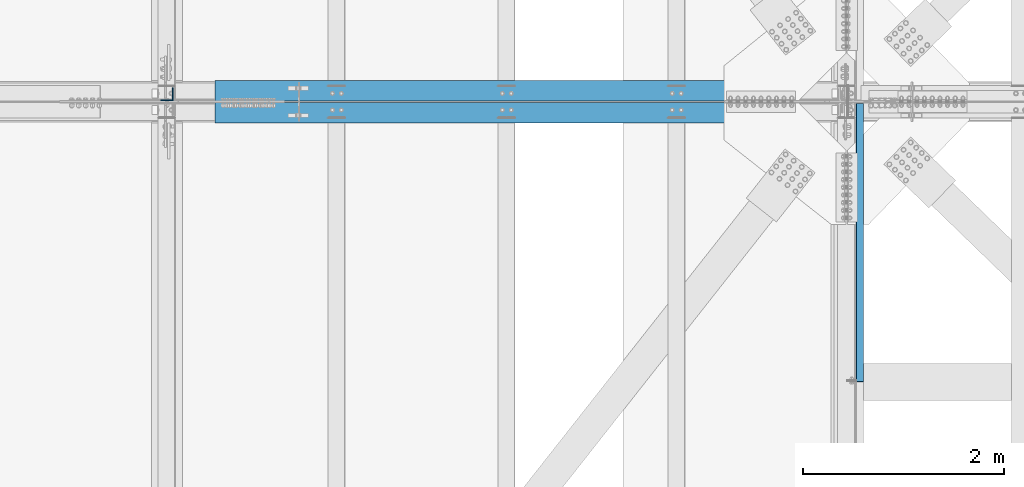
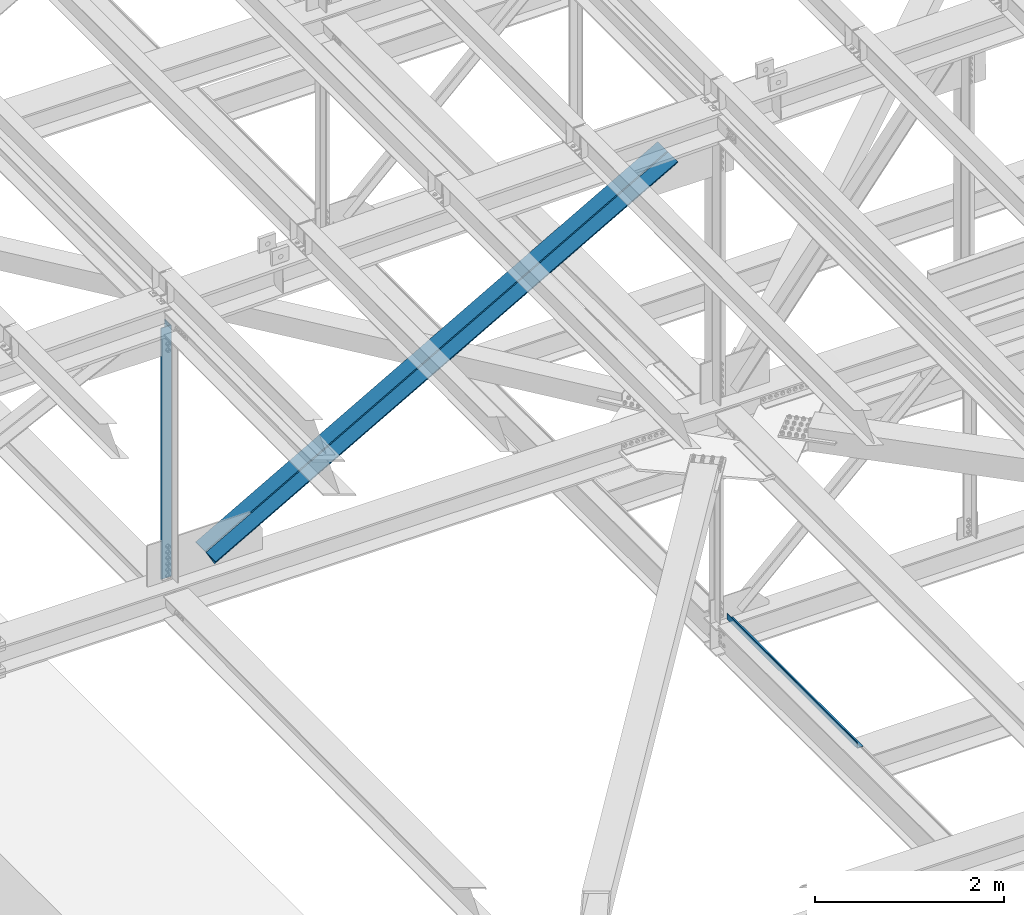
# One storey, part 1839 of 3843: 2 beams, 2 members, 4 elements without a shape of their own.
"""IFC2X3 building model written with IfcOpenShell, lengths in millimetres."""

from ifc_helpers import new_model, si_unit, frame, origin_with_axes, place, context, subcontext, project, spatial, faceted_brep, material, type_object, element, aggregate, save


model = new_model("IFC2X3")

# Units and contexts
model_context = context("Model", 3, precision=1e-05, world=origin_with_axes())
body_context = subcontext(model_context, "Body", "Model", "MODEL_VIEW")
ifc_project = project(units=[si_unit("LENGTHUNIT", "METRE", prefix="MILLI"), si_unit("AREAUNIT", "SQUARE_METRE"), si_unit("VOLUMEUNIT", "CUBIC_METRE"), si_unit("MASSUNIT", "GRAM", prefix="KILO"), si_unit("TIMEUNIT", "SECOND"), si_unit("PLANEANGLEUNIT", "RADIAN"), si_unit("SOLIDANGLEUNIT", "STERADIAN"), si_unit("THERMODYNAMICTEMPERATUREUNIT", "DEGREE_CELSIUS"), si_unit("LUMINOUSINTENSITYUNIT", "LUMEN")], contexts=[model_context])

# Site, building, storey
site_placement = place(None, origin_with_axes())
site = spatial("IfcSite", under=ifc_project, at=site_placement, CompositionType="ELEMENT")
building_placement = place(site_placement, origin_with_axes())
building = spatial("IfcBuilding", under=site, at=building_placement, Name="Undefined", CompositionType="ELEMENT")
storey_placement = place(building_placement, origin_with_axes())
storey = spatial("IfcBuildingStorey", under=building, at=storey_placement, Name="Undefined", CompositionType="ELEMENT", Elevation=0.0)

# Assembly, beam
assembly_1_placement = place(storey_placement, origin_with_axes())
assembly_1 = element("IfcElementAssembly", 1, at=assembly_1_placement, inside=storey, Name="BENT_PLATE", AssemblyPlace="NOTDEFINED", PredefinedType="RIGID_FRAME")
ifc_material_1 = material(Name="STEEL/A36")
beam_type_1 = type_object("IfcBeamType", PredefinedType="NOTDEFINED")
beam_1_placement = place(assembly_1_placement, frame((77179.4875000007, 40799.54475, 39627.1749999995), z_axis=(0.0, 1.0, 0.0), x_axis=(-1.0, 0.0, 0.0)))
beam_1 = element("IfcBeam", 2, at=beam_1_placement, type_object=beam_type_1, material=ifc_material_1, Name="BENT_PLATE", context=body_context, shape_type="Brep", body=[
    faceted_brep([(69.8500000005442, 3.17500000000291, -1379.53850000001), (73.0239999527839, 0.00100004768319195, -1382.7125), (0.0, 0.00100003396073589, -1382.71249999999), (0.0, 3.17500000000291, -1379.53850000001), (69.850000000617, 73.0249999994776, -1379.53850000001), (73.0239999528567, 73.0249999997322, -1382.7125), (0.0, 3.17500000000291, 1382.71249999999), (69.8500000005442, 3.17500000000291, 1382.71249999999), (0.0, -3.17500000000291, -1382.71249999999), (0.0, -3.17500000000291, 1382.71249999999), (76.2000000005355, -3.17500000000291, -1382.71249999999), (76.2000000005355, -3.17500000000291, 1382.71249999999), (69.850000000617, 73.0249999994776, 1382.71249999999), (76.2000000006228, 73.024999999463, 1382.71249999999), (76.2000000006228, 73.024999999463, -1382.71249999999)], [[[0, 1, 2, 3]], [[4, 5, 1, 0]], [[6, 7, 0, 3]], [[8, 9, 6, 3, 2]], [[9, 8, 10, 11]], [[7, 12, 4, 0]], [[7, 6, 9, 11, 13, 12]], [[11, 10, 14, 13]], [[5, 14, 10, 8, 2, 1]], [[12, 13, 14, 5, 4]]]),
])
aggregate(assembly_1, [beam_1])

assembly_2_placement = place(storey_placement, origin_with_axes())
assembly_2 = element("IfcElementAssembly", 3, at=assembly_2_placement, inside=storey, Name="ANGLE", AssemblyPlace="NOTDEFINED", PredefinedType="RIGID_FRAME")
ifc_material_2 = material(Name="STEEL/A572-50")
beam_type_2 = type_object("IfcBeamType", Name="L5X5X3/8", PredefinedType="NOTDEFINED")
beam_2_placement = place(assembly_2_placement, frame((70256.4000000496, 42275.125, 46014.141723883), z_axis=(-1.0, 0.0, 0.0), x_axis=(0.0, 0.0, -1.0)))
beam_2 = element("IfcBeam", 4, at=beam_2_placement, type_object=beam_type_2, material=ifc_material_2, Name="ANGLE", ObjectType="L5X5X3/8", context=body_context, shape_type="Brep", body=[
    faceted_brep([(224.880704416319, 63.5, -63.4999999990832), (224.880704417243, 63.5, 63.5000000009168), (3477.3658520948, 63.5, 63.5000000141881), (3477.36585209388, 63.5, -63.4999999858119), (224.880704417243, 53.9749999999985, 63.5000000009168), (3477.3658520948, 53.9749999999985, 63.5000000141881), (224.880704416384, 53.9749999999985, -53.9749999990891), (3477.36585209394, 53.9749999999985, -53.9749999858032), (224.880704416384, -63.5, -53.9749999990891), (3477.36585209394, -63.5, -53.9749999858032), (224.880704416319, -63.5, -63.4999999990832), (3477.36585209388, -63.5, -63.4999999858119)], [[[0, 1, 2, 3]], [[1, 4, 5, 2]], [[4, 6, 7, 5]], [[6, 8, 9, 7]], [[8, 10, 11, 9]], [[10, 0, 3, 11]], [[5, 7, 9, 11, 3, 2]], [[10, 8, 6, 4, 1, 0]]]),
])
aggregate(assembly_2, [beam_2])

# Assembly, member
assembly_3_placement = place(storey_placement, origin_with_axes())
assembly_3 = element("IfcElementAssembly", 5, at=assembly_3_placement, inside=storey, Name="ANGLE", AssemblyPlace="NOTDEFINED", PredefinedType="RIGID_FRAME")
member_type = type_object("IfcMemberType", Name="L8X8X1/2", PredefinedType="NOTDEFINED")
member_1_placement = place(assembly_3_placement, frame((77012.7999990214, 42313.225, 46150.0685625803), z_axis=(0.0, 1.0, 0.0), x_axis=(-0.870311256498383, 0.0, -0.492502098282034)))
member_1 = element("IfcMember", 6, at=member_1_placement, type_object=member_type, material=ifc_material_2, Name="ANGLE", ObjectType="L8X8X1/2", context=body_context, shape_type="Brep", body=[
    faceted_brep([(655.825570851608, 101.59999999818, -101.599999999999), (655.825570851608, 101.59999999818, 101.599999999999), (7159.08650570616, 101.599999982704, 101.599999999999), (7159.08650570616, 101.599999982704, -101.599999999999), (655.82557085171, 88.8999999982116, 101.599999999999), (7159.08650570626, 88.8999999827429, 101.599999999999), (655.82557085171, 88.8999999982116, -88.9000000000015), (7159.08650570626, 88.8999999827429, -88.9000000000015), (655.825570852903, -101.600000001301, -88.9000000000015), (7159.08650570746, -101.60000001677, -88.9000000000015), (655.825570852903, -101.600000001301, -101.599999999999), (7159.08650570746, -101.60000001677, -101.599999999999)], [[[0, 1, 2, 3]], [[1, 4, 5, 2]], [[4, 6, 7, 5]], [[6, 8, 9, 7]], [[8, 10, 11, 9]], [[10, 0, 3, 11]], [[5, 7, 9, 11, 3, 2]], [[10, 8, 6, 4, 1, 0]]]),
])
aggregate(assembly_3, [member_1])

assembly_4_placement = place(storey_placement, origin_with_axes())
assembly_4 = element("IfcElementAssembly", 7, at=assembly_4_placement, inside=storey, Name="ANGLE", AssemblyPlace="NOTDEFINED", PredefinedType="RIGID_FRAME")
member_2_placement = place(assembly_4_placement, frame((70256.4, 42090.975, 42326.6764672527), z_axis=(0.0, -1.0, 0.0), x_axis=(0.870311256498384, 0.0, 0.492502098282032)))
member_2 = element("IfcMember", 8, at=member_2_placement, type_object=member_type, material=ifc_material_2, Name="ANGLE", ObjectType="L8X8X1/2", context=body_context, shape_type="Brep", body=[
    faceted_brep([(604.113096367393, 101.600000001184, -101.599999999999), (604.113096367393, 101.600000001184, 101.599999999999), (7107.37403122195, 101.60000001666, 101.599999999999), (7107.37403122195, 101.60000001666, -101.599999999999), (604.11309636732, 88.9000000012084, 101.599999999999), (7107.37403122187, 88.9000000166843, 101.599999999999), (604.11309636732, 88.9000000012084, -88.9000000000015), (7107.37403122187, 88.9000000166843, -88.9000000000015), (604.113096366098, -101.59999999829, -88.9000000000015), (7107.37403122065, -101.599999982821, -88.9000000000015), (604.113096366098, -101.59999999829, -101.599999999999), (7107.37403122065, -101.599999982821, -101.599999999999)], [[[0, 1, 2, 3]], [[1, 4, 5, 2]], [[4, 6, 7, 5]], [[6, 8, 9, 7]], [[8, 10, 11, 9]], [[10, 0, 3, 11]], [[5, 7, 9, 11, 3, 2]], [[10, 8, 6, 4, 1, 0]]]),
])
aggregate(assembly_4, [member_2])

save(model, "model.ifc")
